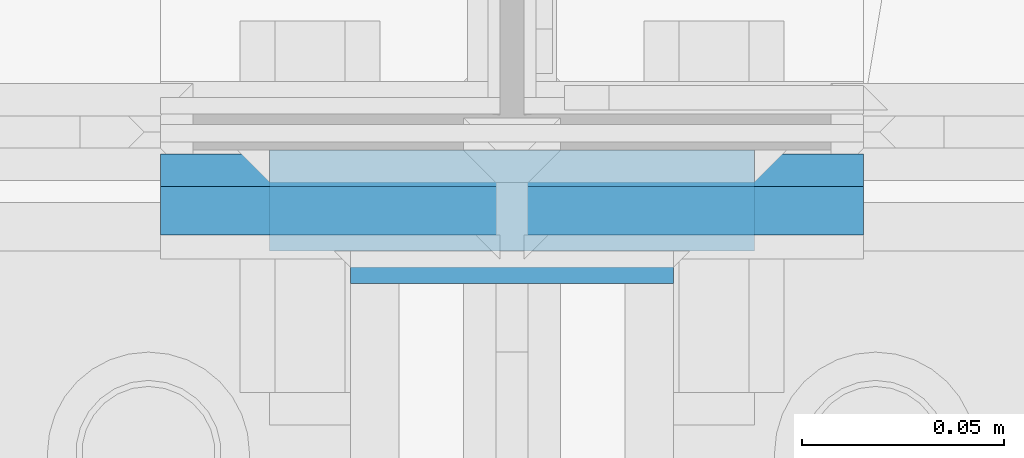
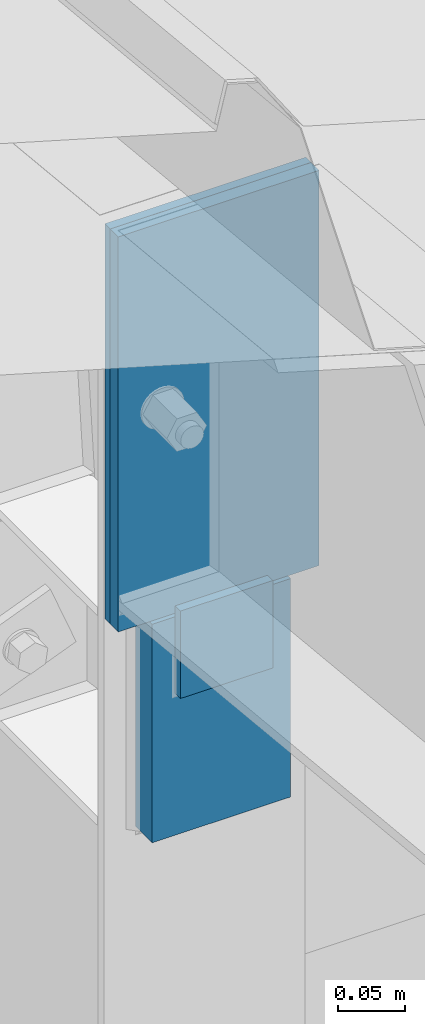
# One storey, part 23 of 709: 4 columns, 3 elements without a shape of their own.
"""IFC4 building model written with IfcOpenShell, lengths in millimetres."""

from ifc_helpers import new_model, si_unit, direction, frame, origin_with_axes, place, context, subcontext, project, spatial, line, indexed_curve, outline, extrude, material, element, aggregate, save


model = new_model("IFC4")

# Units and contexts
model_context = context("Model", 3, precision=0.2, world=origin_with_axes(), true_north=direction((0.0, 1.0)))
body_context = subcontext(model_context, "Body", "Model", "MODEL_VIEW")
ifc_project = project(units=[si_unit("LENGTHUNIT", "METRE", prefix="MILLI"), si_unit("AREAUNIT", "SQUARE_METRE"), si_unit("VOLUMEUNIT", "CUBIC_METRE"), si_unit("MASSUNIT", "GRAM", prefix="KILO"), si_unit("TIMEUNIT", "SECOND"), si_unit("PLANEANGLEUNIT", "RADIAN"), si_unit("SOLIDANGLEUNIT", "STERADIAN"), si_unit("THERMODYNAMICTEMPERATUREUNIT", "DEGREE_CELSIUS"), si_unit("LUMINOUSINTENSITYUNIT", "LUMEN")], contexts=[model_context])

# Site, building, storey
site_placement = place(None, origin_with_axes())
site = spatial("IfcSite", under=ifc_project, at=site_placement, CompositionType="ELEMENT")
building_placement = place(site_placement, origin_with_axes())
building = spatial("IfcBuilding", under=site, at=building_placement, Name="Undefined", CompositionType="ELEMENT")
storey_placement = place(building_placement, origin_with_axes())
storey = spatial("IfcBuildingStorey", under=building, at=storey_placement, Name="Undefined", CompositionType="ELEMENT", Elevation=0.0)

# Assembly, column
assembly_1_placement = place(storey_placement, frame((28000.0, 21654.0, 7089.70002), z_axis=(-1.0, 0.0, 0.0), x_axis=(0.0, -0.9950371902, 0.099503719)))
assembly_1 = element("IfcElementAssembly", 1, at=assembly_1_placement, inside=storey)
ifc_material = material(Name="C355-6", Category="STEEL")
column_1_placement = place(assembly_1_placement, frame((-4.15556, -192.30372, 0.0), z_axis=(0.9950371902, -0.099503719, 0.0), x_axis=(0.099503719, 0.9950371902, 0.0)))
column_1 = element("IfcColumn", 2, at=column_1_placement, material=ifc_material, ObjectType="457", context=body_context, shape_type="SolidModel", body=[
    extrude(outline(indexed_curve([(-6.0, -87.0), (6.0, -87.0), (6.0, 87.0), (-6.0, 87.0)], segments=[line(1, 2, 3, 4, 1)])), frame((0.0, 0.0, 0.0), z_axis=(-1.0, 0.0, 0.0), x_axis=(0.0, 0.0, 1.0)), (0.0, 0.0, -1.0), 361.7257),
])
aggregate(assembly_1, [column_1])

assembly_2_placement = place(storey_placement, frame((28000.0, 21649.0, 6897.93718), z_axis=(0.0, -1.0, 0.0), x_axis=(0.0, 0.0, 1.0)))
assembly_2 = element("IfcElementAssembly", 3, at=assembly_2_placement, inside=storey)
column_2_placement = place(assembly_2_placement, origin_with_axes())
column_2 = element("IfcColumn", 4, at=column_2_placement, material=ifc_material, ObjectType="458", context=body_context, shape_type="SolidModel", body=[
    extrude(outline(indexed_curve([(-4.0, -87.0), (4.0, -87.0), (4.0, 87.0), (-4.0, 87.0)], segments=[line(1, 2, 3, 4, 1)])), frame((0.0, 0.0, 0.0), z_axis=(-1.0, 0.0, 0.0), x_axis=(0.0, 0.0, 1.0)), (0.0, 0.0, -1.0), 361.7257),
])
aggregate(assembly_2, [column_2])

# Assembly, columns
assembly_3_placement = place(storey_placement, frame((28000.0, 21827.0, -200.0), z_axis=(-1.0, 0.0, 0.0), x_axis=(0.0, 0.0, 1.0)))
assembly_3 = element("IfcElementAssembly", 5, at=assembly_3_placement, inside=storey)
column_3_placement = place(assembly_3_placement, frame((6897.93718, -185.5, 0.0), z_axis=(0.0, -1.0, 0.0), x_axis=(1.0, 0.0, 0.0)))
column_3 = element("IfcColumn", 6, at=column_3_placement, material=ifc_material, ObjectType="459", context=body_context, shape_type="SolidModel", body=[
    extrude(outline(indexed_curve([(-12.5, -60.0), (12.5, -60.0), (12.5, 60.0), (-12.5, 60.0)], segments=[line(1, 2, 3, 4, 1)])), frame((0.0, 0.0, 0.0), z_axis=(-1.0, 0.0, 0.0), x_axis=(0.0, 0.0, 1.0)), (0.0, 0.0, -1.0), 200.0),
])
column_4_placement = place(assembly_3_placement, frame((7027.93718, -202.0, 0.0), z_axis=(0.0, -1.0, 0.0), x_axis=(1.0, 0.0, 0.0)))
column_4 = element("IfcColumn", 7, at=column_4_placement, material=ifc_material, ObjectType="462", context=body_context, shape_type="SolidModel", body=[
    extrude(outline(indexed_curve([(-4.0, -40.0), (4.0, -40.0), (4.0, 40.0), (-4.0, 40.0)], segments=[line(1, 2, 3, 4, 1)])), frame((0.0, 0.0, 0.0), z_axis=(-1.0, 0.0, 0.0), x_axis=(0.0, 0.0, 1.0)), (0.0, 0.0, -1.0), 80.0),
])
aggregate(assembly_3, [column_3, column_4])

save(model, "model.ifc")
